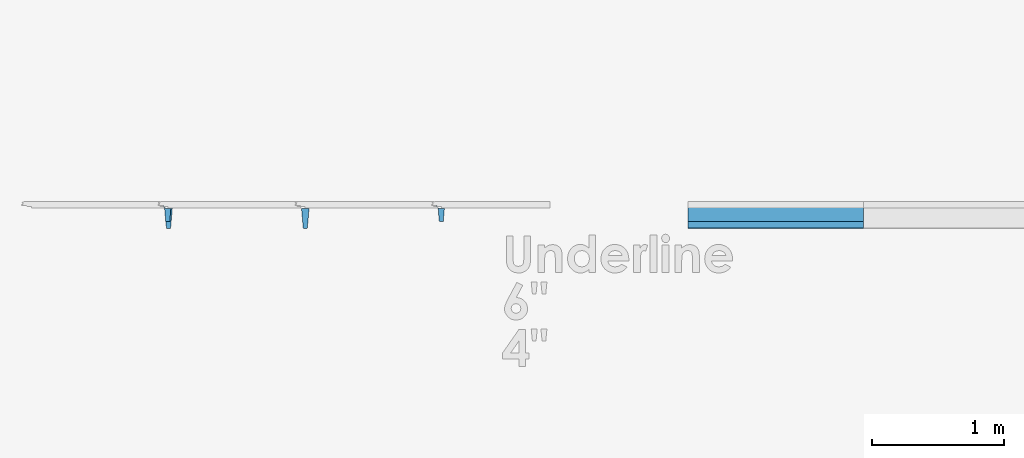
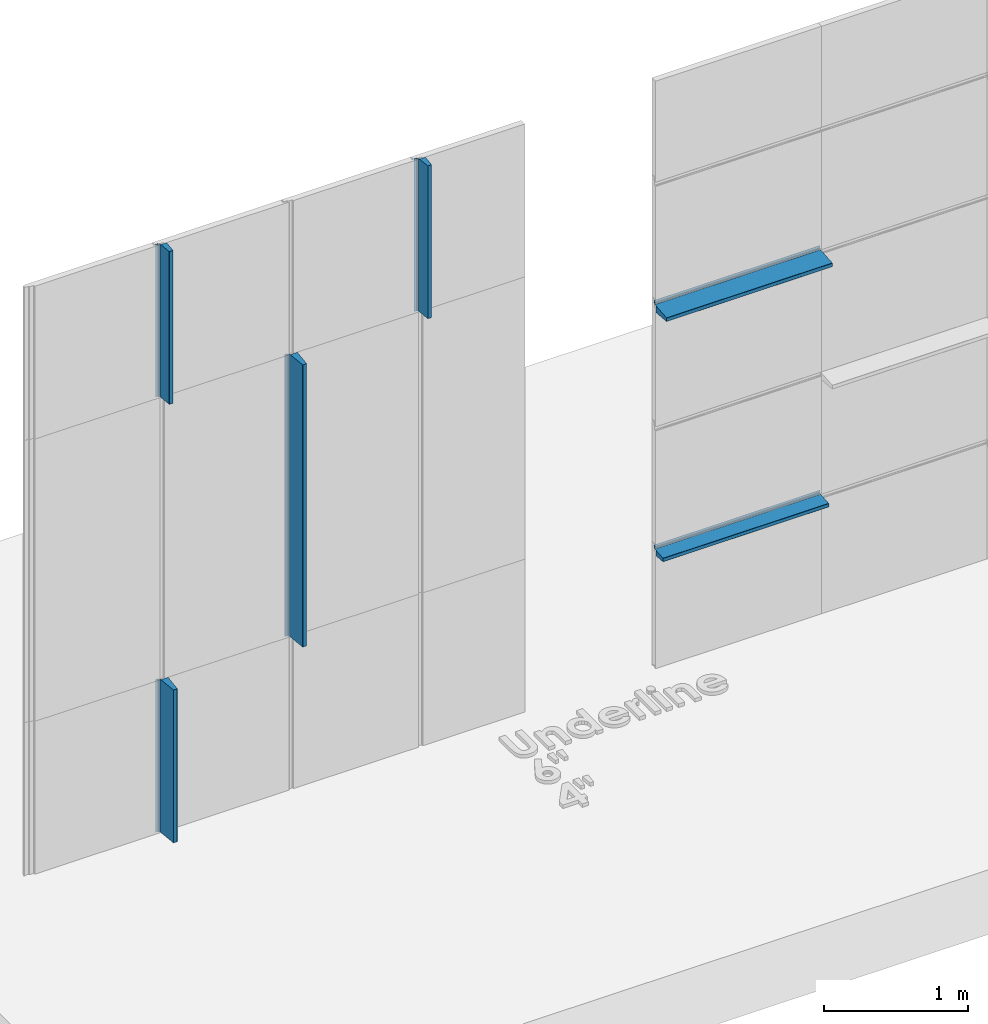
# One storey, part 1 of 6: 6 members, 2 elements without a shape of their own.
"""IFC2X3 building model written with IfcOpenShell, lengths in millimetres."""

from ifc_helpers import new_model, entity, si_unit, converted_unit, derived_unit, direction, frame, frame_2d, origin, place, context, subcontext, project, spatial, polyline, circle_curve, parameter, trimmed, segment, composite_curve, outline, extrude, source, transform, mapped, material, type_object, type_shapes, element, aggregate, save


model = new_model("IFC2X3")

# Units and contexts
model_context = context("Model", 3, precision=0.01, world=origin(), true_north=direction((6.123031769111886e-17, 1.0)))
body_context = subcontext(model_context, "Body", "Model", "MODEL_VIEW")
ifc_project = project(units=[si_unit("LENGTHUNIT", "METRE", prefix="MILLI"), si_unit("AREAUNIT", "SQUARE_METRE"), si_unit("VOLUMEUNIT", "CUBIC_METRE"), converted_unit("PLANEANGLEUNIT", "DEGREE", entity("IfcPlaneAngleMeasure", 0.017453292519943278), si_unit("PLANEANGLEUNIT", "RADIAN"), dimensions=[0, 0, 0, 0, 0, 0, 0]), si_unit("MASSUNIT", "GRAM", prefix="KILO"), derived_unit("MASSDENSITYUNIT", [(si_unit("MASSUNIT", "GRAM", prefix="KILO"), 1), (si_unit("LENGTHUNIT", "METRE"), -3)]), derived_unit("IONCONCENTRATIONUNIT", [(si_unit("MASSUNIT", "GRAM", prefix="KILO"), 1), (si_unit("LENGTHUNIT", "METRE"), -3)]), derived_unit("MOMENTOFINERTIAUNIT", [(si_unit("LENGTHUNIT", "METRE"), 4)]), si_unit("TIMEUNIT", "SECOND"), si_unit("FREQUENCYUNIT", "HERTZ"), si_unit("THERMODYNAMICTEMPERATUREUNIT", "DEGREE_CELSIUS"), derived_unit("THERMALTRANSMITTANCEUNIT", [(si_unit("MASSUNIT", "GRAM", prefix="KILO"), 1), (si_unit("THERMODYNAMICTEMPERATUREUNIT", "KELVIN"), -1), (si_unit("TIMEUNIT", "SECOND"), -3)]), derived_unit("THERMALCONDUCTANCEUNIT", [(si_unit("MASSUNIT", "GRAM", prefix="KILO"), 1), (si_unit("THERMODYNAMICTEMPERATUREUNIT", "KELVIN"), -1), (si_unit("TIMEUNIT", "SECOND"), -3), (si_unit("LENGTHUNIT", "METRE"), 1)]), derived_unit("VOLUMETRICFLOWRATEUNIT", [(si_unit("LENGTHUNIT", "METRE", prefix="DECI"), 3), (si_unit("TIMEUNIT", "SECOND"), -1)]), derived_unit("MASSFLOWRATEUNIT", [(si_unit("MASSUNIT", "GRAM", prefix="KILO"), 1), (si_unit("TIMEUNIT", "SECOND"), -1)]), derived_unit("ROTATIONALFREQUENCYUNIT", [(si_unit("TIMEUNIT", "SECOND"), -1)]), si_unit("ELECTRICCURRENTUNIT", "AMPERE"), si_unit("ELECTRICVOLTAGEUNIT", "VOLT"), si_unit("POWERUNIT", "WATT"), si_unit("FORCEUNIT", "NEWTON", prefix="KILO"), si_unit("ILLUMINANCEUNIT", "LUX"), si_unit("LUMINOUSFLUXUNIT", "LUMEN"), si_unit("LUMINOUSINTENSITYUNIT", "CANDELA"), si_unit("ENERGYUNIT", "JOULE"), derived_unit("USERDEFINED", [(si_unit("MASSUNIT", "GRAM", prefix="KILO"), -1), (si_unit("LENGTHUNIT", "METRE"), -2), (si_unit("TIMEUNIT", "SECOND"), 3), (si_unit("LUMINOUSFLUXUNIT", "LUMEN"), 1)]), derived_unit("USERDEFINED", [(si_unit("MASSUNIT", "GRAM", prefix="KILO"), 1), (si_unit("TIMEUNIT", "SECOND"), -3), (si_unit("LENGTHUNIT", "METRE"), 3), (si_unit("ELECTRICCURRENTUNIT", "AMPERE"), -2)]), derived_unit("SOUNDPOWERUNIT", [(si_unit("MASSUNIT", "GRAM", prefix="KILO"), 1), (si_unit("TIMEUNIT", "SECOND"), -3), (si_unit("LENGTHUNIT", "METRE"), 2)]), derived_unit("SOUNDPRESSUREUNIT", [(si_unit("MASSUNIT", "GRAM", prefix="KILO"), 1), (si_unit("LENGTHUNIT", "METRE"), -1), (si_unit("TIMEUNIT", "SECOND"), -2)]), derived_unit("LINEARVELOCITYUNIT", [(si_unit("LENGTHUNIT", "METRE"), 1), (si_unit("TIMEUNIT", "SECOND"), -1)]), si_unit("PRESSUREUNIT", "PASCAL"), derived_unit("USERDEFINED", [(si_unit("MASSUNIT", "GRAM", prefix="KILO"), 1), (si_unit("LENGTHUNIT", "METRE"), -2), (si_unit("TIMEUNIT", "SECOND"), -2)]), derived_unit("LINEARFORCEUNIT", [(si_unit("MASSUNIT", "GRAM", prefix="KILO"), 1), (si_unit("TIMEUNIT", "SECOND"), -2)]), derived_unit("PLANARFORCEUNIT", [(si_unit("MASSUNIT", "GRAM", prefix="KILO"), 1), (si_unit("LENGTHUNIT", "METRE"), -1), (si_unit("TIMEUNIT", "SECOND"), -2)]), derived_unit("SPECIFICHEATCAPACITYUNIT", [(si_unit("THERMODYNAMICTEMPERATUREUNIT", "KELVIN"), -1), (si_unit("LENGTHUNIT", "METRE"), 2), (si_unit("TIMEUNIT", "SECOND"), -2)]), derived_unit("HEATFLUXDENSITYUNIT", [(si_unit("MASSUNIT", "GRAM", prefix="KILO"), 1), (si_unit("TIMEUNIT", "SECOND"), -3)]), derived_unit("HEATINGVALUEUNIT", [(si_unit("LENGTHUNIT", "METRE"), 2), (si_unit("TIMEUNIT", "SECOND"), -2)]), derived_unit("VAPORPERMEABILITYUNIT", [(si_unit("LENGTHUNIT", "METRE"), -1), (si_unit("TIMEUNIT", "SECOND"), 1)]), derived_unit("DYNAMICVISCOSITYUNIT", [(si_unit("MASSUNIT", "GRAM", prefix="KILO"), 1), (si_unit("TIMEUNIT", "SECOND"), -1), (si_unit("LENGTHUNIT", "METRE"), -1)]), derived_unit("THERMALEXPANSIONCOEFFICIENTUNIT", [(si_unit("THERMODYNAMICTEMPERATUREUNIT", "KELVIN"), -1)]), derived_unit("MODULUSOFELASTICITYUNIT", [(si_unit("MASSUNIT", "GRAM", prefix="KILO"), 1), (si_unit("LENGTHUNIT", "METRE"), -1), (si_unit("TIMEUNIT", "SECOND"), -2)]), derived_unit("ISOTHERMALMOISTURECAPACITYUNIT", [(si_unit("MASSUNIT", "GRAM", prefix="KILO"), -1), (si_unit("LENGTHUNIT", "METRE"), 3)]), derived_unit("MOISTUREDIFFUSIVITYUNIT", [(si_unit("TIMEUNIT", "SECOND"), -1), (si_unit("LENGTHUNIT", "METRE"), 2)]), derived_unit("MASSPERLENGTHUNIT", [(si_unit("MASSUNIT", "GRAM", prefix="KILO"), 1), (si_unit("LENGTHUNIT", "METRE"), -1)]), derived_unit("THERMALRESISTANCEUNIT", [(si_unit("MASSUNIT", "GRAM", prefix="KILO"), -1), (si_unit("TIMEUNIT", "SECOND"), 3), (si_unit("THERMODYNAMICTEMPERATUREUNIT", "KELVIN"), 1)]), derived_unit("ACCELERATIONUNIT", [(si_unit("LENGTHUNIT", "METRE"), 1), (si_unit("TIMEUNIT", "SECOND"), -2)]), derived_unit("ANGULARVELOCITYUNIT", [(si_unit("TIMEUNIT", "SECOND"), -1), (si_unit("PLANEANGLEUNIT", "RADIAN"), 1)]), derived_unit("LINEARSTIFFNESSUNIT", [(si_unit("MASSUNIT", "GRAM", prefix="KILO"), 1), (si_unit("TIMEUNIT", "SECOND"), -2)]), derived_unit("WARPINGCONSTANTUNIT", [(si_unit("LENGTHUNIT", "METRE"), 6)]), derived_unit("LINEARMOMENTUNIT", [(si_unit("MASSUNIT", "GRAM", prefix="KILO"), 1), (si_unit("LENGTHUNIT", "METRE"), 1), (si_unit("TIMEUNIT", "SECOND"), -2)]), derived_unit("TORQUEUNIT", [(si_unit("MASSUNIT", "GRAM", prefix="KILO"), 1), (si_unit("LENGTHUNIT", "METRE"), 2), (si_unit("TIMEUNIT", "SECOND"), -2)])], contexts=[model_context])

# Site, building, storey
site_placement = place(None, origin())
site = spatial("IfcSite", under=ifc_project, at=site_placement, CompositionType="ELEMENT")
building_placement = place(site_placement, origin())
building = spatial("IfcBuilding", under=site, at=building_placement, Name="de", CompositionType="ELEMENT")
storey_placement = place(building_placement, origin())
storey = spatial("IfcBuildingStorey", under=building, at=storey_placement, CompositionType="ELEMENT", Elevation=0.0)

# Curtain wall, members
curtain_wall_type_1 = type_object("IfcCurtainWallType", Name="Parede cortina:PV_Painel Evolution PIR 50", PredefinedType="NOTDEFINED")
curtain_wall_1_placement = place(storey_placement, origin())
curtain_wall_1 = element("IfcCurtainWall", 1, at=curtain_wall_1_placement, inside=storey, type_object=curtain_wall_type_1, Name="Parede cortina:PV_Painel Evolution PIR 50", ObjectType="Parede cortina:PV_Painel Evolution PIR 50")
ifc_material_1 = material(Name="RAL8000")
member_type_1 = type_object("IfcMemberType", Name="Montante retangular:Vertical - 4pol - RAL8000", PredefinedType="MULLION", material=ifc_material_1)
shared_shape_1 = source(origin(), body_context, "Body", "SweptSolid", [
    extrude(outline(composite_curve([segment(trimmed(circle_curve(frame_2d((23.569647144933867, 10.767226450808582), x_axis=(0.0, -1.0)), 2.0), [parameter(180.00000000012034)], [parameter(269.9999999999999)], True, "PARAMETER"), True, "CONTINUOUS"), segment(polyline([(21.569647144929675, 10.767226450808597), (21.569647144929675, 4.601685270896727)]), True, "CONTINUOUS"), segment(trimmed(circle_curve(frame_2d((19.56964714493386, 4.601685270896713), x_axis=(0.0, -1.0)), 2.0), [parameter(4.94407441067773)], [parameter(90.00000000000009)], True, "PARAMETER"), False, "CONTINUOUS"), segment(polyline([(19.742013804962653, 2.609126680915221), (-92.20271951510335, -7.074673779298337)]), True, "CONTINUOUS"), segment(trimmed(circle_curve(frame_2d((-92.03035285506617, -9.067232369279793), x_axis=(0.0, -1.0)), 2.0), [parameter(184.94407441091784)], [parameter(269.9999999999999)], True, "PARAMETER"), True, "CONTINUOUS"), segment(polyline([(-94.03035285507033, -9.067232369279779), (-94.03035285507033, -35.39831472910359)]), True, "CONTINUOUS"), segment(trimmed(circle_curve(frame_2d((-92.03035285506611, -35.3983147291036), x_axis=(0.0, -1.0)), 2.0), [parameter(269.9999999999999)], [parameter(355.055925589082)], True, "PARAMETER"), True, "CONTINUOUS"), segment(polyline([(-92.20271951510335, -37.390873319085074), (5.905144913720896, -45.87771280254756)]), True, "CONTINUOUS"), segment(trimmed(circle_curve(frame_2d((6.077511573758109, -43.885154212566064), x_axis=(0.0, -1.0)), 2.0), [parameter(355.05592558908296)], [parameter(90.0000000000008)], True, "PARAMETER"), True, "CONTINUOUS"), segment(polyline([(8.077511573753917, -43.88515421256605), (8.077511573753746, 0.5963520951609809)]), True, "CONTINUOUS"), segment(polyline([(8.077511573753746, 0.5963520951609809), (19.82819713497917, 1.61284738592445)]), True, "CONTINUOUS"), segment(trimmed(circle_curve(frame_2d((19.56964714493386, 4.601685270896713), x_axis=(0.0, -1.0)), 3.0), [parameter(4.944074410718084)], [parameter(90.0000000000005)], True, "PARAMETER"), True, "CONTINUOUS"), segment(polyline([(22.569647144929647, 4.601685270896734), (22.569647144929647, 10.767226450808593)]), True, "CONTINUOUS"), segment(trimmed(circle_curve(frame_2d((23.569647144933867, 10.767226450808582), x_axis=(0.0, -1.0)), 1.0), [parameter(180.00000000024082)], [parameter(269.99999999999943)], True, "PARAMETER"), False, "CONTINUOUS"), segment(polyline([(23.569647144929657, 11.767226450808625), (27.569647144929696, 11.767226450808625)]), True, "CONTINUOUS"), segment(trimmed(circle_curve(frame_2d((27.56964714493387, 14.767226450808622), x_axis=(0.0, -1.0)), 3.0), [parameter(359.9999999999203)], [parameter(90.00000000000044)], True, "PARAMETER"), True, "CONTINUOUS"), segment(polyline([(30.569647144929657, 14.76722645080864), (30.569647144929657, 32.267226450808636)]), True, "CONTINUOUS"), segment(polyline([(30.569647144929657, 32.267226450808636), (29.569647144929665, 32.267226450808636)]), True, "CONTINUOUS"), segment(polyline([(29.569647144929665, 32.267226450808636), (29.569647144929665, 14.767226450808632)]), True, "CONTINUOUS"), segment(trimmed(circle_curve(frame_2d((27.56964714493387, 14.767226450808622), x_axis=(0.0, -1.0)), 2.0), [parameter(359.99999999987944)], [parameter(90.00000000000009)], True, "PARAMETER"), False, "CONTINUOUS"), segment(polyline([(27.569647144929696, 12.7672264508086), (23.569647144929657, 12.7672264508086)]), True, "CONTINUOUS")], self_intersect=False)), frame((32.267226450808636, 34.70403432094011, -1300.0), z_axis=(0.0, 0.0, -1.0), x_axis=(0.0, -1.0, 0.0)), (0.0, 0.0, -1.0), 1299.9999999999995),
])
type_shapes(member_type_1, [shared_shape_1])
member_1_placement = place(curtain_wall_1_placement, frame((-3690.051034202845, 792.6007792258602, 3700.0), z_axis=(0.0, 0.0, -1.0), x_axis=(1.0, 0.0, 0.0)))
member_1 = element("IfcMember", 2, at=member_1_placement, type_object=member_type_1, material=ifc_material_1, Name="Montante retangular:Vertical - 4pol - RAL8000", ObjectType="Montante retangular:Vertical - 4pol - RAL8000", context=body_context, shape_type="MappedRepresentation", body=[
    mapped(shared_shape_1, transform((0.0, 0.0, 0.0), scale=1.0)),
])
member_2_placement = place(curtain_wall_1_placement, frame((-1610.0510342028456, 792.6007792258551, 3700.0), z_axis=(0.0, 0.0, -1.0), x_axis=(1.0, 0.0, 0.0)))
member_2 = element("IfcMember", 3, at=member_2_placement, type_object=member_type_1, material=ifc_material_1, Name="Montante retangular:Vertical - 4pol - RAL8000", ObjectType="Montante retangular:Vertical - 4pol - RAL8000", context=body_context, shape_type="MappedRepresentation", body=[
    mapped(shared_shape_1, transform((0.0, 0.0, 0.0), scale=1.0)),
])
ifc_material_2 = material(Name="RAL5010")
member_type_2 = type_object("IfcMemberType", Name="Montante retangular:Vertical - 6pol - RAL5010", PredefinedType="MULLION", material=ifc_material_2)
shared_shape_2 = source(origin(), body_context, "Body", "SweptSolid", [
    extrude(outline(composite_curve([segment(trimmed(circle_curve(frame_2d((32.99351776581997, 12.708419144261732), x_axis=(0.0, -1.0)), 2.0), [parameter(180.00000000012062)], [parameter(269.9999999999999)], True, "PARAMETER"), True, "CONTINUOUS"), segment(polyline([(30.993517765815767, 12.708419144261743), (30.993517765815767, 6.542877964349877)]), True, "CONTINUOUS"), segment(trimmed(circle_curve(frame_2d((28.993517765819966, 6.542877964349863), x_axis=(0.0, -1.0)), 2.0), [parameter(4.944074410678391)], [parameter(90.00000000000009)], True, "PARAMETER"), False, "CONTINUOUS"), segment(polyline([(29.165884425848784, 4.550319374368371), (-132.59281364375482, -9.442647586670333)]), True, "CONTINUOUS"), segment(trimmed(circle_curve(frame_2d((-132.42044698371757, -11.435206176651832), x_axis=(0.0, -1.0)), 2.0), [parameter(184.94407441091928)], [parameter(269.9999999999999)], True, "PARAMETER"), True, "CONTINUOUS"), segment(polyline([(-134.42044698372177, -11.43520617665181), (-134.42044698372177, -39.150371581458366)]), True, "CONTINUOUS"), segment(trimmed(circle_curve(frame_2d((-132.4204469837175, -39.150371581458366), x_axis=(0.0, -1.0)), 2.0), [parameter(269.9999999999999)], [parameter(355.0559255890825)], True, "PARAMETER"), True, "CONTINUOUS"), segment(polyline([(-132.5928136437547, -41.14293017143988), (14.785503681813477, -53.891919559465116)]), True, "CONTINUOUS"), segment(trimmed(circle_curve(frame_2d((14.960698790436943, -51.86666410382664), x_axis=(0.0, -1.0)), 2.0328189753830666), [parameter(355.0559255890837)], [parameter(90.00000000000009)], True, "PARAMETER"), True, "CONTINUOUS"), segment(polyline([(16.993517765815803, -51.86666410382664), (16.993517765815636, 2.493611879546293)]), True, "CONTINUOUS"), segment(polyline([(16.993517765815636, 2.493611879546286), (30.16588442584876, 3.6330899643242667)]), True, "CONTINUOUS"), segment(trimmed(circle_curve(frame_2d((29.99351776581996, 5.625648554305727), x_axis=(0.0, -1.0)), 2.0), [parameter(4.944074410678849)], [parameter(90.00000000000044)], True, "PARAMETER"), True, "CONTINUOUS"), segment(polyline([(31.993517765815778, 5.625648554305737), (31.993517765815778, 11.708419144261768)]), True, "CONTINUOUS"), segment(trimmed(circle_curve(frame_2d((33.99351776581996, 11.708419144261757), x_axis=(0.0, -1.0)), 2.0), [parameter(180.00000000012014)], [parameter(269.99999999999955)], True, "PARAMETER"), False, "CONTINUOUS"), segment(polyline([(33.99351776581577, 13.708419144261775), (37.99351776581577, 13.708419144261775)]), True, "CONTINUOUS"), segment(trimmed(circle_curve(frame_2d((37.993517765819966, 15.708419144261793), x_axis=(0.0, -1.0)), 2.0), [parameter(359.99999999987966)], [parameter(90.00000000000044)], True, "PARAMETER"), True, "CONTINUOUS"), segment(polyline([(39.99351776581579, 15.708419144261807), (39.99351776581579, 35.208419144261725)]), True, "CONTINUOUS"), segment(polyline([(39.99351776581579, 35.208419144261725), (38.993517765815774, 35.208419144261725)]), True, "CONTINUOUS"), segment(polyline([(38.993517765815774, 35.208419144261725), (38.993517765815774, 16.708419144261782)]), True, "CONTINUOUS"), segment(trimmed(circle_curve(frame_2d((36.99351776581997, 16.70841914426177), x_axis=(0.0, -1.0)), 2.0), [parameter(359.9999999998802)], [parameter(90.00000000000009)], True, "PARAMETER"), False, "CONTINUOUS"), segment(polyline([(36.993517765815795, 14.70841914426175), (32.99351776581575, 14.70841914426175)]), True, "CONTINUOUS")], self_intersect=False)), frame((35.20841914426172, 43.98809022500579, -1300.0), z_axis=(0.0, 0.0, -1.0), x_axis=(0.0, -1.0, 0.0)), (0.0, 0.0, -1.0), 1299.9999999999995),
])
type_shapes(member_type_2, [shared_shape_2])
member_3_placement = place(curtain_wall_1_placement, frame((-3690.051034202845, 792.6007792258602, 0.0), z_axis=(0.0, 0.0, -1.0), x_axis=(1.0, 0.0, 0.0)))
member_3 = element("IfcMember", 4, at=member_3_placement, type_object=member_type_2, material=ifc_material_2, Name="Montante retangular:Vertical - 6pol - RAL5010", ObjectType="Montante retangular:Vertical - 6pol - RAL5010", context=body_context, shape_type="MappedRepresentation", body=[
    mapped(shared_shape_2, transform((0.0, 0.0, 0.0), scale=1.0)),
])
member_type_3 = type_object("IfcMemberType", Name="Montante retangular:Vertical - 6pol - RAL5010", PredefinedType="MULLION", material=ifc_material_2)
shared_shape_3 = source(origin(), body_context, "Body", "SweptSolid", [
    extrude(outline(composite_curve([segment(trimmed(circle_curve(frame_2d((32.99351776582268, 12.708419144261732), x_axis=(0.0, -1.0)), 2.0), [parameter(180.00000000022249)], [parameter(269.9999999999999)], True, "PARAMETER"), True, "CONTINUOUS"), segment(polyline([(30.99351776581492, 12.708419144261743), (30.99351776581492, 6.542877964349877)]), True, "CONTINUOUS"), segment(trimmed(circle_curve(frame_2d((28.993517765822673, 6.542877964349863), x_axis=(0.0, -1.0)), 2.0), [parameter(4.944074410576919)], [parameter(90.00000000000009)], True, "PARAMETER"), False, "CONTINUOUS"), segment(polyline([(29.16588442584794, 4.550319374368371), (-132.59281364375568, -9.442647586670333)]), True, "CONTINUOUS"), segment(trimmed(circle_curve(frame_2d((-132.42044698371487, -11.435206176651832), x_axis=(0.0, -1.0)), 2.0), [parameter(184.94407441102072)], [parameter(269.9999999999999)], True, "PARAMETER"), True, "CONTINUOUS"), segment(polyline([(-134.4204469837226, -11.43520617665181), (-134.4204469837226, -39.150371581458366)]), True, "CONTINUOUS"), segment(trimmed(circle_curve(frame_2d((-132.4204469837148, -39.150371581458366), x_axis=(0.0, -1.0)), 2.0), [parameter(269.9999999999999)], [parameter(355.05592558898104)], True, "PARAMETER"), True, "CONTINUOUS"), segment(polyline([(-132.59281364375556, -41.14293017143988), (14.785503681812632, -53.891919559465116)]), True, "CONTINUOUS"), segment(trimmed(circle_curve(frame_2d((14.96069879043965, -51.86666410382664), x_axis=(0.0, -1.0)), 2.0328189753830666), [parameter(355.0559255889839)], [parameter(90.00000000000009)], True, "PARAMETER"), True, "CONTINUOUS"), segment(polyline([(16.993517765814957, -51.86666410382664), (16.99351776581479, 2.493611879546293)]), True, "CONTINUOUS"), segment(polyline([(16.99351776581479, 2.493611879546286), (30.165884425847914, 3.6330899643242667)]), True, "CONTINUOUS"), segment(trimmed(circle_curve(frame_2d((29.993517765822666, 5.625648554305727), x_axis=(0.0, -1.0)), 2.0), [parameter(4.944074410577376)], [parameter(90.00000000000044)], True, "PARAMETER"), True, "CONTINUOUS"), segment(polyline([(31.993517765814932, 5.625648554305737), (31.993517765814932, 11.708419144261768)]), True, "CONTINUOUS"), segment(trimmed(circle_curve(frame_2d((33.99351776582267, 11.708419144261757), x_axis=(0.0, -1.0)), 2.0), [parameter(180.000000000222)], [parameter(269.99999999999955)], True, "PARAMETER"), False, "CONTINUOUS"), segment(polyline([(33.993517765814914, 13.708419144261775), (37.99351776581492, 13.708419144261775)]), True, "CONTINUOUS"), segment(trimmed(circle_curve(frame_2d((37.99351776582267, 15.708419144261793), x_axis=(0.0, -1.0)), 2.0), [parameter(359.99999999977786)], [parameter(90.00000000000044)], True, "PARAMETER"), True, "CONTINUOUS"), segment(polyline([(39.99351776581494, 15.708419144261807), (39.99351776581494, 35.208419144261725)]), True, "CONTINUOUS"), segment(polyline([(39.99351776581494, 35.208419144261725), (38.99351776581493, 35.208419144261725)]), True, "CONTINUOUS"), segment(polyline([(38.99351776581493, 35.208419144261725), (38.99351776581493, 16.708419144261782)]), True, "CONTINUOUS"), segment(trimmed(circle_curve(frame_2d((36.99351776582268, 16.70841914426177), x_axis=(0.0, -1.0)), 2.0), [parameter(359.9999999997783)], [parameter(90.00000000000009)], True, "PARAMETER"), False, "CONTINUOUS"), segment(polyline([(36.99351776581494, 14.70841914426175), (32.99351776581491, 14.70841914426175)]), True, "CONTINUOUS")], self_intersect=False)), frame((35.20841914426172, 43.988090225004946, -2400.0), z_axis=(0.0, 0.0, -1.0), x_axis=(0.0, -1.0, 0.0)), (0.0, 0.0, -1.0), 2400.000000000001),
])
type_shapes(member_type_3, [shared_shape_3])
member_4_placement = place(curtain_wall_1_placement, frame((-2650.051034202845, 792.6007792258575, 1300.0), z_axis=(0.0, 0.0, -1.0), x_axis=(1.0, 0.0, 0.0)))
member_4 = element("IfcMember", 5, at=member_4_placement, type_object=member_type_3, material=ifc_material_2, Name="Montante retangular:Vertical - 6pol - RAL5010", ObjectType="Montante retangular:Vertical - 6pol - RAL5010", context=body_context, shape_type="MappedRepresentation", body=[
    mapped(shared_shape_3, transform((0.0, 0.0, 0.0), scale=1.0)),
])
aggregate(curtain_wall_1, [member_1, member_3, member_4, member_2])

curtain_wall_type_2 = type_object("IfcCurtainWallType", Name="Parede cortina:PH_Painel Evolution PIR 50", PredefinedType="NOTDEFINED")
curtain_wall_2_placement = place(storey_placement, origin())
curtain_wall_2 = element("IfcCurtainWall", 6, at=curtain_wall_2_placement, inside=storey, type_object=curtain_wall_type_2, Name="Parede cortina:PH_Painel Evolution PIR 50", ObjectType="Parede cortina:PH_Painel Evolution PIR 50")
member_type_4 = type_object("IfcMemberType", Name="Montante retangular:Horizontal - 4pol - RAL8000", PredefinedType="MULLION", material=ifc_material_1)
shared_shape_4 = source(origin(), body_context, "Body", "SweptSolid", [
    extrude(outline(composite_curve([segment(trimmed(circle_curve(frame_2d((-10.767226450808597, 23.56964714493416), x_axis=(1.0, 0.0)), 2.0), [parameter(180.0000000001234)], [parameter(269.99999999999955)], True, "PARAMETER"), True, "CONTINUOUS"), segment(polyline([(-10.76722645080861, 21.56964714492986), (-4.601685270896741, 21.56964714492986)]), True, "CONTINUOUS"), segment(trimmed(circle_curve(frame_2d((-4.601685270896727, 19.56964714493415), x_axis=(1.0, 0.0)), 2.0), [parameter(4.944074410675592)], [parameter(90.00000000000044)], True, "PARAMETER"), False, "CONTINUOUS"), segment(polyline([(-2.609126680915235, 19.742013804962873), (7.0746737792983225, -92.20271951510317)]), True, "CONTINUOUS"), segment(trimmed(circle_curve(frame_2d((9.067232369279779, -92.03035285506587), x_axis=(1.0, 0.0)), 2.0), [parameter(184.94407441092025)], [parameter(269.99999999999943)], True, "PARAMETER"), True, "CONTINUOUS"), segment(polyline([(9.067232369279765, -94.03035285507015), (35.398314729103575, -94.03035285507015)]), True, "CONTINUOUS"), segment(trimmed(circle_curve(frame_2d((35.39831472910359, -92.0303528550658), x_axis=(1.0, 0.0)), 2.0), [parameter(269.99999999999943)], [parameter(355.0559255890776)], True, "PARAMETER"), True, "CONTINUOUS"), segment(polyline([(37.39087331908506, -92.20271951510317), (45.87771280254755, 5.905144913721081)]), True, "CONTINUOUS"), segment(trimmed(circle_curve(frame_2d((43.88515421256605, 6.0775115737584), x_axis=(1.0, 0.0)), 2.0), [parameter(355.055925589079)], [parameter(90.00000000000034)], True, "PARAMETER"), True, "CONTINUOUS"), segment(polyline([(43.885154212566036, 8.077511573754101), (-0.5963520951609951, 8.077511573753931)]), True, "CONTINUOUS"), segment(polyline([(-0.5963520951609951, 8.077511573753931), (-1.6128473859244643, 19.82819713497939)]), True, "CONTINUOUS"), segment(trimmed(circle_curve(frame_2d((-4.601685270896727, 19.56964714493415), x_axis=(1.0, 0.0)), 3.0), [parameter(4.944074410715998)], [parameter(90.00000000000009)], True, "PARAMETER"), True, "CONTINUOUS"), segment(polyline([(-4.601685270896748, 22.56964714492983), (-10.767226450808607, 22.56964714492983)]), True, "CONTINUOUS"), segment(trimmed(circle_curve(frame_2d((-10.767226450808597, 23.56964714493416), x_axis=(1.0, 0.0)), 1.0), [parameter(180.000000000247)], [parameter(269.9999999999999)], True, "PARAMETER"), False, "CONTINUOUS"), segment(polyline([(-11.76722645080864, 23.569647144929842), (-11.76722645080864, 27.56964714492988)]), True, "CONTINUOUS"), segment(trimmed(circle_curve(frame_2d((-14.767226450808636, 27.569647144934162), x_axis=(1.0, 0.0)), 3.0), [parameter(359.9999999999176)], [parameter(90.00000000000009)], True, "PARAMETER"), True, "CONTINUOUS"), segment(polyline([(-14.767226450808653, 30.569647144929842), (-32.26722645080865, 30.569647144929842)]), True, "CONTINUOUS"), segment(polyline([(-32.26722645080865, 30.569647144929842), (-32.26722645080865, 29.56964714492985)]), True, "CONTINUOUS"), segment(polyline([(-32.26722645080865, 29.56964714492985), (-14.767226450808646, 29.56964714492985)]), True, "CONTINUOUS"), segment(trimmed(circle_curve(frame_2d((-14.767226450808636, 27.569647144934162), x_axis=(1.0, 0.0)), 2.0), [parameter(359.99999999987733)], [parameter(90.00000000000044)], True, "PARAMETER"), False, "CONTINUOUS"), segment(polyline([(-12.767226450808614, 27.56964714492988), (-12.767226450808614, 23.569647144929842)]), True, "CONTINUOUS")], self_intersect=False)), frame((-32.26722645080865, 34.704034320940295, -1333.3333333333333), z_axis=(0.0, 0.0, 1.0), x_axis=(-1.0, 0.0, 0.0)), (0.0, 0.0, 1.0), 1333.3333333333335),
])
type_shapes(member_type_4, [shared_shape_4])
member_5_placement = place(curtain_wall_2_placement, frame((1654.6678106414718, 792.600779225847, 1040.0), z_axis=(1.0, 0.0, 0.0), x_axis=(0.0, 0.0, 1.0)))
member_5 = element("IfcMember", 7, at=member_5_placement, type_object=member_type_4, material=ifc_material_1, Name="Montante retangular:Horizontal - 4pol - RAL8000", ObjectType="Montante retangular:Horizontal - 4pol - RAL8000", context=body_context, shape_type="MappedRepresentation", body=[
    mapped(shared_shape_4, transform((0.0, 0.0, 0.0), scale=1.0)),
])
member_type_5 = type_object("IfcMemberType", Name="Montante retangular:Horizontal - 6pol - RAL5010", PredefinedType="MULLION", material=ifc_material_2)
shared_shape_5 = source(origin(), body_context, "Body", "SweptSolid", [
    extrude(outline(composite_curve([segment(trimmed(circle_curve(frame_2d((-12.708419144261761, 32.99351776582026), x_axis=(1.0, 0.0)), 2.0), [parameter(180.00000000012372)], [parameter(269.99999999999955)], True, "PARAMETER"), True, "CONTINUOUS"), segment(polyline([(-12.708419144261772, 30.993517765815945), (-6.5428779643499055, 30.993517765815945)]), True, "CONTINUOUS"), segment(trimmed(circle_curve(frame_2d((-6.542877964349891, 28.99351776582025), x_axis=(1.0, 0.0)), 2.0), [parameter(4.944074410675286)], [parameter(90.00000000000044)], True, "PARAMETER"), False, "CONTINUOUS"), segment(polyline([(-4.550319374368399, 29.16588442584896), (9.442647586670304, -132.59281364375465)]), True, "CONTINUOUS"), segment(trimmed(circle_curve(frame_2d((11.435206176651803, -132.42044698371728), x_axis=(1.0, 0.0)), 2.0), [parameter(184.94407441092028)], [parameter(269.99999999999943)], True, "PARAMETER"), True, "CONTINUOUS"), segment(polyline([(11.435206176651782, -134.42044698372152), (39.15037158145834, -134.42044698372152)]), True, "CONTINUOUS"), segment(trimmed(circle_curve(frame_2d((39.15037158145834, -132.42044698371723), x_axis=(1.0, 0.0)), 2.0), [parameter(269.99999999999943)], [parameter(355.0559255890777)], True, "PARAMETER"), True, "CONTINUOUS"), segment(polyline([(41.14293017143985, -132.5928136437546), (53.89191955946509, 14.785503681813655)]), True, "CONTINUOUS"), segment(trimmed(circle_curve(frame_2d((51.866664103826615, 14.960698790437228), x_axis=(1.0, 0.0)), 2.0328189753830666), [parameter(355.0559255890807)], [parameter(89.99999999999963)], True, "PARAMETER"), True, "CONTINUOUS"), segment(polyline([(51.866664103826615, 16.99351776581598), (-2.4936118795463216, 16.993517765815813)]), True, "CONTINUOUS"), segment(polyline([(-2.4936118795463145, 16.993517765815813), (-3.633089964324295, 30.165884425848937)]), True, "CONTINUOUS"), segment(trimmed(circle_curve(frame_2d((-5.625648554305755, 29.993517765820243), x_axis=(1.0, 0.0)), 2.0), [parameter(4.944074410674829)], [parameter(90.00000000000009)], True, "PARAMETER"), True, "CONTINUOUS"), segment(polyline([(-5.625648554305766, 31.993517765815955), (-11.708419144261796, 31.993517765815955)]), True, "CONTINUOUS"), segment(trimmed(circle_curve(frame_2d((-11.708419144261786, 33.99351776582025), x_axis=(1.0, 0.0)), 2.0), [parameter(180.00000000012324)], [parameter(269.9999999999999)], True, "PARAMETER"), False, "CONTINUOUS"), segment(polyline([(-13.708419144261804, 33.99351776581594), (-13.708419144261804, 37.993517765815945)]), True, "CONTINUOUS"), segment(trimmed(circle_curve(frame_2d((-15.708419144261821, 37.99351776582025), x_axis=(1.0, 0.0)), 2.0), [parameter(359.9999999998766)], [parameter(90.00000000000009)], True, "PARAMETER"), True, "CONTINUOUS"), segment(polyline([(-15.708419144261835, 39.993517765815966), (-35.208419144261754, 39.993517765815966)]), True, "CONTINUOUS"), segment(polyline([(-35.208419144261754, 39.993517765815966), (-35.208419144261754, 38.99351776581595)]), True, "CONTINUOUS"), segment(polyline([(-35.208419144261754, 38.99351776581595), (-16.70841914426181, 38.99351776581595)]), True, "CONTINUOUS"), segment(trimmed(circle_curve(frame_2d((-16.7084191442618, 36.99351776582026), x_axis=(1.0, 0.0)), 2.0), [parameter(359.99999999987705)], [parameter(90.00000000000044)], True, "PARAMETER"), False, "CONTINUOUS"), segment(polyline([(-14.708419144261779, 36.993517765815966), (-14.708419144261779, 32.99351776581593)]), True, "CONTINUOUS")], self_intersect=False)), frame((-35.20841914426175, 43.98809022500597, -1333.3333333333335), z_axis=(0.0, 0.0, 1.0), x_axis=(-1.0, 0.0, 0.0)), (0.0, 0.0, 1.0), 1333.333333333334),
])
type_shapes(member_type_5, [shared_shape_5])
member_6_placement = place(curtain_wall_2_placement, frame((1654.6678106414715, 792.600779225847, 3120.0), z_axis=(1.0, 0.0, 0.0), x_axis=(0.0, 0.0, 1.0)))
member_6 = element("IfcMember", 8, at=member_6_placement, type_object=member_type_5, material=ifc_material_2, Name="Montante retangular:Horizontal - 6pol - RAL5010", ObjectType="Montante retangular:Horizontal - 6pol - RAL5010", context=body_context, shape_type="MappedRepresentation", body=[
    mapped(shared_shape_5, transform((0.0, 0.0, 0.0), scale=1.0)),
])
aggregate(curtain_wall_2, [member_5, member_6])

save(model, "model.ifc")
